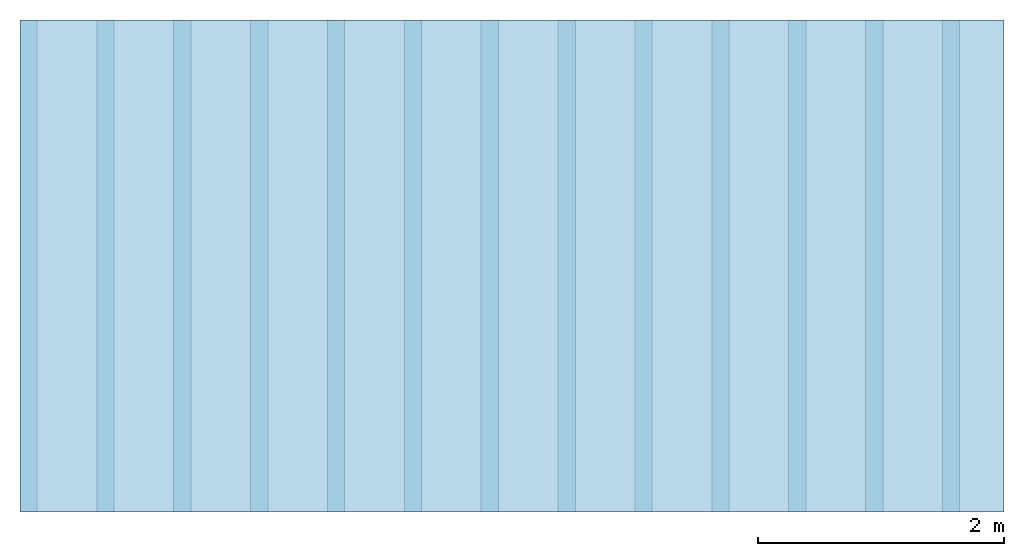
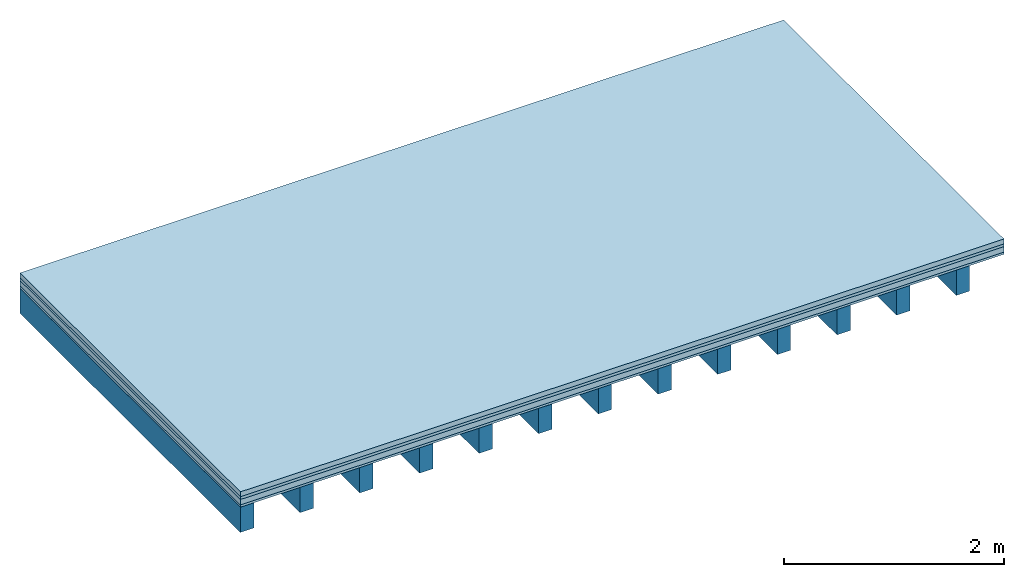
# One storey: 4 plates, 1 member, 1 element without a shape of its own.
"""IFC4 building model written with IfcOpenShell, lengths in metres."""

from ifc_helpers import new_model, si_unit, derived_unit, direction, frame, frame_2d, origin, origin_with_axes, place, context, project, spatial, rectangle, extrude, material, layer, layer_set, type_object, element, aggregate, save


model = new_model("IFC4")

# Units and contexts
plan_context = context("Plan", 3, precision=1e-05, world=origin(), true_north=direction((0.0, 1.0)))
model_context = context("Model", 3, precision=1e-05, world=origin(), true_north=direction((0.0, 1.0)))
ifc_project = project(units=[si_unit("LENGTHUNIT", "METRE"), derived_unit("SOUNDPRESSUREUNIT", [(si_unit("PRESSUREUNIT", "PASCAL", prefix="MICRO"), 0)]), si_unit("ENERGYUNIT", "JOULE", prefix="MEGA"), si_unit("MASSUNIT", "GRAM", prefix="KILO"), derived_unit("THERMALTRANSMITTANCEUNIT", [(si_unit("POWERUNIT", "WATT"), 1), (si_unit("AREAUNIT", "SQUARE_METRE"), -1), (si_unit("THERMODYNAMICTEMPERATUREUNIT", "KELVIN"), -1)]), derived_unit("AREADENSITYUNIT", [(si_unit("MASSUNIT", "GRAM", prefix="KILO"), 1), (si_unit("AREAUNIT", "SQUARE_METRE"), -1)]), derived_unit("USERDEFINED", [(si_unit("ENERGYUNIT", "JOULE", prefix="MEGA"), 1), (si_unit("AREAUNIT", "SQUARE_METRE"), -1)])], contexts=[plan_context, model_context])

# Site, building, storey
site = spatial("IfcSite", under=ifc_project)
building_placement = place(None, origin())
building = spatial("IfcBuilding", under=site, at=building_placement)
storey_placement = place(building_placement, origin())
storey = spatial("IfcBuildingStorey", under=building, at=storey_placement)

# Slab, member, plates
ifc_material_1 = material(Category="04.005")
ifc_layer_1 = layer(ifc_material_1, 0.055, Name="On-material")
ifc_material_2 = material()
ifc_layer_2 = layer(ifc_material_2, 0.03, Name="Impact sound insulation")
ifc_material_3 = material(Category="03.011")
ifc_layer_3 = layer(ifc_material_3, 0.06, Name="on Supporting structure")
ifc_material_4 = material(Category="07.001")
ifc_layer_4 = layer(ifc_material_4, 0.025, Name="Sub-floor")
ifc_material_5 = material(Name="of the art")
ifc_layer_5 = layer(ifc_material_5, 0.0, Name="Bond")
ifc_layer_6 = layer(None, 0.28, Name="Supporting structure")
ifc_layer_set = layer_set([ifc_layer_1, ifc_layer_2, ifc_layer_3, ifc_layer_4, ifc_layer_5, ifc_layer_6])
slab_type = type_object("IfcSlabType", Name="A0233", PredefinedType="NOTDEFINED", material=ifc_layer_set)
slab_placement = place(None, frame((0.0, 0.0, 0.0), z_axis=(0.0, 0.0, -1.0), x_axis=(1.0, 0.0, 0.0)))
slab = element("IfcSlab", 1, at=slab_placement, inside=storey, type_object=slab_type, material=ifc_layer_set, Name="Slab #1")
ifc_material_6 = material()
member_placement = place(slab_placement, origin())
member = element("IfcMember", 2, at=member_placement, material=ifc_material_6, Name="Supporting structure", context=plan_context, shape_type="SweptSolid", body=[
    extrude(rectangle(XDim=0.14, YDim=0.28, at=frame_2d((0.07, 0.14), x_axis=(1.0, 0.0))), frame((0.0, 4.0, 0.17), z_axis=(0.0, -1.0, 0.0), x_axis=(1.0, 0.0, 0.0)), (0.0, 0.0, 1.0), 4.0),
    extrude(rectangle(XDim=0.14, YDim=0.28, at=frame_2d((0.07, 0.14), x_axis=(1.0, 0.0))), frame((0.625, 4.0, 0.17), z_axis=(0.0, -1.0, 0.0), x_axis=(1.0, 0.0, 0.0)), (0.0, 0.0, 1.0), 4.0),
    extrude(rectangle(XDim=0.14, YDim=0.28, at=frame_2d((0.07, 0.14), x_axis=(1.0, 0.0))), frame((1.25, 4.0, 0.17), z_axis=(0.0, -1.0, 0.0), x_axis=(1.0, 0.0, 0.0)), (0.0, 0.0, 1.0), 4.0),
    extrude(rectangle(XDim=0.14, YDim=0.28, at=frame_2d((0.07, 0.14), x_axis=(1.0, 0.0))), frame((1.875, 4.0, 0.17), z_axis=(0.0, -1.0, 0.0), x_axis=(1.0, 0.0, 0.0)), (0.0, 0.0, 1.0), 4.0),
    extrude(rectangle(XDim=0.14, YDim=0.28, at=frame_2d((0.07, 0.14), x_axis=(1.0, 0.0))), frame((2.5, 4.0, 0.17), z_axis=(0.0, -1.0, 0.0), x_axis=(1.0, 0.0, 0.0)), (0.0, 0.0, 1.0), 4.0),
    extrude(rectangle(XDim=0.14, YDim=0.28, at=frame_2d((0.07, 0.14), x_axis=(1.0, 0.0))), frame((3.125, 4.0, 0.17), z_axis=(0.0, -1.0, 0.0), x_axis=(1.0, 0.0, 0.0)), (0.0, 0.0, 1.0), 4.0),
    extrude(rectangle(XDim=0.14, YDim=0.28, at=frame_2d((0.07, 0.14), x_axis=(1.0, 0.0))), frame((3.75, 4.0, 0.17), z_axis=(0.0, -1.0, 0.0), x_axis=(1.0, 0.0, 0.0)), (0.0, 0.0, 1.0), 4.0),
    extrude(rectangle(XDim=0.14, YDim=0.28, at=frame_2d((0.07, 0.14), x_axis=(1.0, 0.0))), frame((4.375, 4.0, 0.17), z_axis=(0.0, -1.0, 0.0), x_axis=(1.0, 0.0, 0.0)), (0.0, 0.0, 1.0), 4.0),
    extrude(rectangle(XDim=0.14, YDim=0.28, at=frame_2d((0.07, 0.14), x_axis=(1.0, 0.0))), frame((5.0, 4.0, 0.17), z_axis=(0.0, -1.0, 0.0), x_axis=(1.0, 0.0, 0.0)), (0.0, 0.0, 1.0), 4.0),
    extrude(rectangle(XDim=0.14, YDim=0.28, at=frame_2d((0.07, 0.14), x_axis=(1.0, 0.0))), frame((5.625, 4.0, 0.17), z_axis=(0.0, -1.0, 0.0), x_axis=(1.0, 0.0, 0.0)), (0.0, 0.0, 1.0), 4.0),
    extrude(rectangle(XDim=0.14, YDim=0.28, at=frame_2d((0.07, 0.14), x_axis=(1.0, 0.0))), frame((6.25, 4.0, 0.17), z_axis=(0.0, -1.0, 0.0), x_axis=(1.0, 0.0, 0.0)), (0.0, 0.0, 1.0), 4.0),
    extrude(rectangle(XDim=0.14, YDim=0.28, at=frame_2d((0.07, 0.14), x_axis=(1.0, 0.0))), frame((6.875, 4.0, 0.17), z_axis=(0.0, -1.0, 0.0), x_axis=(1.0, 0.0, 0.0)), (0.0, 0.0, 1.0), 4.0),
    extrude(rectangle(XDim=0.14, YDim=0.28, at=frame_2d((0.07, 0.14), x_axis=(1.0, 0.0))), frame((7.5, 4.0, 0.17), z_axis=(0.0, -1.0, 0.0), x_axis=(1.0, 0.0, 0.0)), (0.0, 0.0, 1.0), 4.0),
])
plate_1_placement = place(slab_placement, origin())
plate_1 = element("IfcPlate", 3, at=plate_1_placement, material=ifc_material_1, Name="On-material", context=plan_context, shape_type="SweptSolid", body=[
    extrude(rectangle(XDim=8.0, YDim=4.0, at=frame_2d((4.0, 2.0), x_axis=(1.0, 0.0))), origin_with_axes(), (0.0, 0.0, 1.0), 0.055),
])
plate_2_placement = place(slab_placement, origin())
plate_2 = element("IfcPlate", 4, at=plate_2_placement, material=ifc_material_2, Name="Impact sound insulation", context=plan_context, shape_type="SweptSolid", body=[
    extrude(rectangle(XDim=8.0, YDim=4.0, at=frame_2d((4.0, 2.0), x_axis=(1.0, 0.0))), frame((0.0, 0.0, 0.055), z_axis=(0.0, 0.0, 1.0), x_axis=(1.0, 0.0, 0.0)), (0.0, 0.0, 1.0), 0.03),
])
plate_3_placement = place(slab_placement, origin())
plate_3 = element("IfcPlate", 5, at=plate_3_placement, material=ifc_material_3, Name="on Supporting structure", context=plan_context, shape_type="SweptSolid", body=[
    extrude(rectangle(XDim=8.0, YDim=4.0, at=frame_2d((4.0, 2.0), x_axis=(1.0, 0.0))), frame((0.0, 0.0, 0.085), z_axis=(0.0, 0.0, 1.0), x_axis=(1.0, 0.0, 0.0)), (0.0, 0.0, 1.0), 0.06),
])
plate_4_placement = place(slab_placement, origin())
plate_4 = element("IfcPlate", 6, at=plate_4_placement, material=ifc_material_4, Name="Sub-floor", context=plan_context, shape_type="SweptSolid", body=[
    extrude(rectangle(XDim=8.0, YDim=4.0, at=frame_2d((4.0, 2.0), x_axis=(1.0, 0.0))), frame((0.0, 0.0, 0.145), z_axis=(0.0, 0.0, 1.0), x_axis=(1.0, 0.0, 0.0)), (0.0, 0.0, 1.0), 0.025),
])
aggregate(slab, [plate_1, plate_2, plate_3, plate_4, member])

save(model, "model.ifc")
